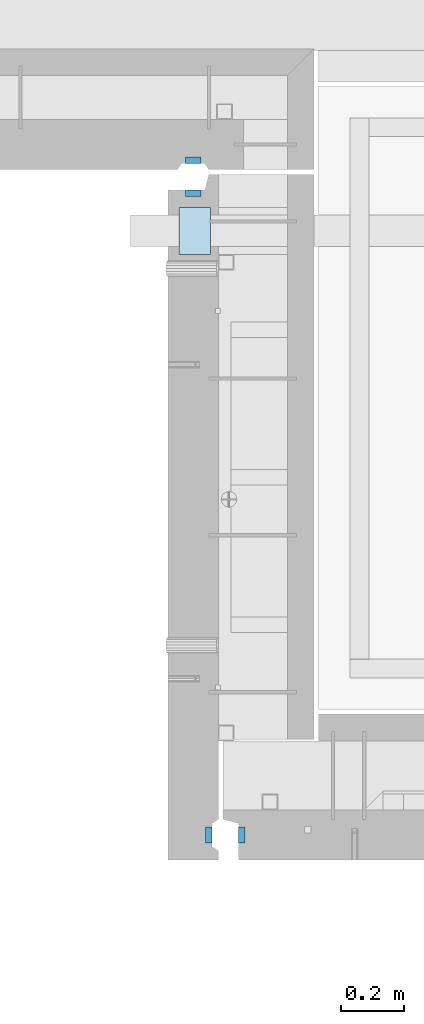
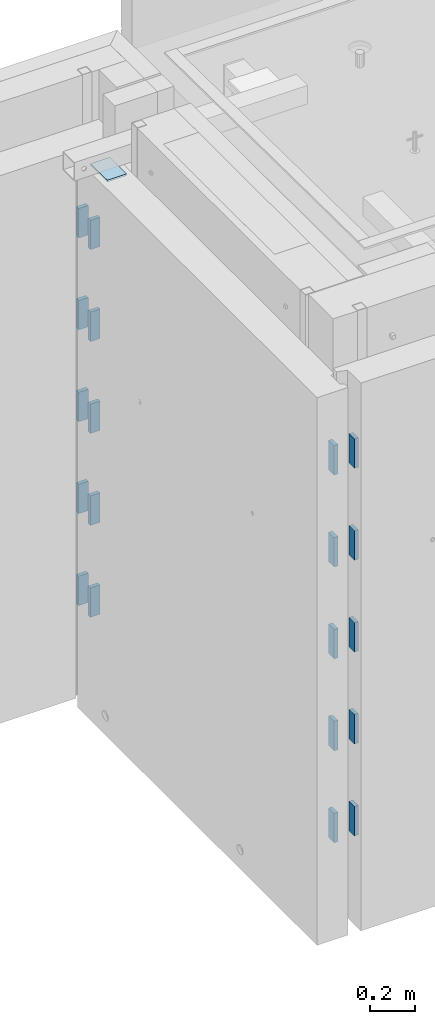
# One storey, part 167 of 264: 21 plates, 24 elements without a shape of their own.
"""IFC2X3 building model written with IfcOpenShell, lengths in millimetres."""

from ifc_helpers import new_model, si_unit, frame, origin_with_axes, place, context, subcontext, project, spatial, faceted_brep, material, type_object, element, aggregate, save


model = new_model("IFC2X3")

# Units and contexts
model_context = context("Model", 3, precision=1e-05, world=origin_with_axes())
body_context = subcontext(model_context, "Body", "Model", "MODEL_VIEW")
ifc_project = project(units=[si_unit("LENGTHUNIT", "METRE", prefix="MILLI"), si_unit("AREAUNIT", "SQUARE_METRE"), si_unit("VOLUMEUNIT", "CUBIC_METRE"), si_unit("MASSUNIT", "GRAM", prefix="KILO"), si_unit("TIMEUNIT", "SECOND"), si_unit("PLANEANGLEUNIT", "RADIAN"), si_unit("SOLIDANGLEUNIT", "STERADIAN"), si_unit("THERMODYNAMICTEMPERATUREUNIT", "DEGREE_CELSIUS"), si_unit("LUMINOUSINTENSITYUNIT", "LUMEN")], contexts=[model_context])

# Site, building, storey
site_placement = place(None, origin_with_axes())
site = spatial("IfcSite", under=ifc_project, at=site_placement, CompositionType="ELEMENT")
building_placement = place(site_placement, origin_with_axes())
building = spatial("IfcBuilding", under=site, at=building_placement, CompositionType="ELEMENT")
storey_placement = place(building_placement, origin_with_axes())
storey = spatial("IfcBuildingStorey", under=building, at=storey_placement, Name="K", CompositionType="ELEMENT", Elevation=0.0)

# Assemblies, plates
assembly_1_placement = place(storey_placement, origin_with_axes())
assembly_1 = element("IfcElementAssembly", 1, at=assembly_1_placement, inside=storey, AssemblyPlace="NOTDEFINED", PredefinedType="REINFORCEMENT_UNIT")
assembly_2_placement = place(assembly_1_placement, origin_with_axes())
assembly_2 = element("IfcElementAssembly", 2, at=assembly_2_placement, Name="Steel Assembly", AssemblyPlace="NOTDEFINED", PredefinedType="RIGID_FRAME")
ifc_material = material(Name="STEEL/Steel_Undefined")
plate_type_1 = type_object("IfcPlateType", PredefinedType="NOTDEFINED")
plate_1_placement = place(assembly_2_placement, frame((31404.996380743, 22535.0011705213, 81052.5), z_axis=(0.0, 1.0, 0.0), x_axis=(-1.0, 3.00000001838171e-08, 0.0)))
plate_1 = element("IfcPlate", 3, at=plate_1_placement, type_object=plate_type_1, material=ifc_material, Name="VL_080", context=body_context, shape_type="Brep", body=[
    faceted_brep([(0.0, -80.0, 0.0), (0.0, -80.0, 20.0), (0.0, 80.0, 20.0), (0.0, 80.0, 0.0), (50.0, -80.0, 20.0), (50.0, 80.0, 20.0), (50.0, -80.0, 0.0), (50.0, 80.0, 0.0)], [[[0, 1, 2, 3]], [[1, 4, 5, 2]], [[4, 6, 7, 5]], [[6, 0, 3, 7]], [[5, 7, 3, 2]], [[6, 4, 1, 0]]]),
])
aggregate(assembly_2, [plate_1])
assembly_3_placement = place(assembly_1_placement, origin_with_axes())
assembly_3 = element("IfcElementAssembly", 4, at=assembly_3_placement, Name="Steel Assembly", AssemblyPlace="NOTDEFINED", PredefinedType="RIGID_FRAME")
plate_2_placement = place(assembly_3_placement, frame((31404.996380743, 22535.0011705213, 80552.5), z_axis=(0.0, 1.0, 0.0), x_axis=(-1.0, 3.00000001838171e-08, 0.0)))
plate_2 = element("IfcPlate", 5, at=plate_2_placement, type_object=plate_type_1, material=ifc_material, Name="VL_080", context=body_context, shape_type="Brep", body=[
    faceted_brep([(0.0, -80.0, 0.0), (0.0, -80.0, 20.0), (0.0, 80.0, 20.0), (0.0, 80.0, 0.0), (50.0, -80.0, 20.0), (50.0, 80.0, 20.0), (50.0, -80.0, 0.0), (50.0, 80.0, 0.0)], [[[0, 1, 2, 3]], [[1, 4, 5, 2]], [[4, 6, 7, 5]], [[6, 0, 3, 7]], [[5, 7, 3, 2]], [[6, 4, 1, 0]]]),
])
aggregate(assembly_3, [plate_2])
assembly_4_placement = place(assembly_1_placement, origin_with_axes())
assembly_4 = element("IfcElementAssembly", 6, at=assembly_4_placement, Name="Steel Assembly", AssemblyPlace="NOTDEFINED", PredefinedType="RIGID_FRAME")
plate_3_placement = place(assembly_4_placement, frame((31404.996380743, 22535.0011705213, 80052.5), z_axis=(0.0, 1.0, 0.0), x_axis=(-1.0, 3.00000001838171e-08, 0.0)))
plate_3 = element("IfcPlate", 7, at=plate_3_placement, type_object=plate_type_1, material=ifc_material, Name="VL_080", context=body_context, shape_type="Brep", body=[
    faceted_brep([(0.0, -80.0, 0.0), (0.0, -80.0, 20.0), (0.0, 80.0, 20.0), (0.0, 80.0, 0.0), (50.0, -80.0, 20.0), (50.0, 80.0, 20.0), (50.0, -80.0, 0.0), (50.0, 80.0, 0.0)], [[[0, 1, 2, 3]], [[1, 4, 5, 2]], [[4, 6, 7, 5]], [[6, 0, 3, 7]], [[5, 7, 3, 2]], [[6, 4, 1, 0]]]),
])
aggregate(assembly_4, [plate_3])
assembly_5_placement = place(assembly_1_placement, origin_with_axes())
assembly_5 = element("IfcElementAssembly", 8, at=assembly_5_placement, Name="Steel Assembly", AssemblyPlace="NOTDEFINED", PredefinedType="RIGID_FRAME")
plate_4_placement = place(assembly_5_placement, frame((31404.996380743, 22535.0011705213, 79552.5), z_axis=(0.0, 1.0, 0.0), x_axis=(-1.0, 3.00000001838171e-08, 0.0)))
plate_4 = element("IfcPlate", 9, at=plate_4_placement, type_object=plate_type_1, material=ifc_material, Name="VL_080", context=body_context, shape_type="Brep", body=[
    faceted_brep([(0.0, -80.0, 0.0), (0.0, -80.0, 20.0), (0.0, 80.0, 20.0), (0.0, 80.0, 0.0), (50.0, -80.0, 20.0), (50.0, 80.0, 20.0), (50.0, -80.0, 0.0), (50.0, 80.0, 0.0)], [[[0, 1, 2, 3]], [[1, 4, 5, 2]], [[4, 6, 7, 5]], [[6, 0, 3, 7]], [[5, 7, 3, 2]], [[6, 4, 1, 0]]]),
])
aggregate(assembly_5, [plate_4])
assembly_6_placement = place(assembly_1_placement, origin_with_axes())
assembly_6 = element("IfcElementAssembly", 10, at=assembly_6_placement, Name="Steel Assembly", AssemblyPlace="NOTDEFINED", PredefinedType="RIGID_FRAME")
plate_5_placement = place(assembly_6_placement, frame((31404.996380743, 22535.0011705213, 79052.5), z_axis=(0.0, 1.0, 0.0), x_axis=(-1.0, 3.00000001838171e-08, 0.0)))
plate_5 = element("IfcPlate", 11, at=plate_5_placement, type_object=plate_type_1, material=ifc_material, Name="VL_080", context=body_context, shape_type="Brep", body=[
    faceted_brep([(0.0, -80.0, 0.0), (0.0, -80.0, 20.0), (0.0, 80.0, 20.0), (0.0, 80.0, 0.0), (50.0, -80.0, 20.0), (50.0, 80.0, 20.0), (50.0, -80.0, 0.0), (50.0, 80.0, 0.0)], [[[0, 1, 2, 3]], [[1, 4, 5, 2]], [[4, 6, 7, 5]], [[6, 0, 3, 7]], [[5, 7, 3, 2]], [[6, 4, 1, 0]]]),
])
aggregate(assembly_6, [plate_5])

assembly_7_placement = place(storey_placement, origin_with_axes())
assembly_7 = element("IfcElementAssembly", 12, at=assembly_7_placement, inside=storey, AssemblyPlace="NOTDEFINED", PredefinedType="REINFORCEMENT_UNIT")
assembly_8_placement = place(assembly_7_placement, origin_with_axes())
assembly_8 = element("IfcElementAssembly", 13, at=assembly_8_placement, Name="Steel Assembly", AssemblyPlace="NOTDEFINED", PredefinedType="RIGID_FRAME")
plate_6_placement = place(assembly_8_placement, frame((31354.9963411181, 22660.0011546714, 81052.5), z_axis=(0.0, -1.0, 0.0), x_axis=(1.0, 0.0, 0.0)))
plate_6 = element("IfcPlate", 14, at=plate_6_placement, type_object=plate_type_1, material=ifc_material, Name="VL_080", context=body_context, shape_type="Brep", body=[
    faceted_brep([(0.0, -80.0, 0.0), (0.0, -80.0, 20.0), (0.0, 80.0, 20.0), (0.0, 80.0, 0.0), (50.0, -80.0, 20.0), (50.0, 80.0, 20.0), (50.0, -80.0, 0.0), (50.0, 80.0, 0.0)], [[[0, 1, 2, 3]], [[1, 4, 5, 2]], [[4, 6, 7, 5]], [[6, 0, 3, 7]], [[5, 7, 3, 2]], [[6, 4, 1, 0]]]),
])
aggregate(assembly_8, [plate_6])
assembly_9_placement = place(assembly_7_placement, origin_with_axes())
assembly_9 = element("IfcElementAssembly", 15, at=assembly_9_placement, Name="Steel Assembly", AssemblyPlace="NOTDEFINED", PredefinedType="RIGID_FRAME")
plate_7_placement = place(assembly_9_placement, frame((31354.9963411181, 22660.0011546714, 80552.5), z_axis=(0.0, -1.0, 0.0), x_axis=(1.0, 0.0, 0.0)))
plate_7 = element("IfcPlate", 16, at=plate_7_placement, type_object=plate_type_1, material=ifc_material, Name="VL_080", context=body_context, shape_type="Brep", body=[
    faceted_brep([(0.0, -80.0, 0.0), (0.0, -80.0, 20.0), (0.0, 80.0, 20.0), (0.0, 80.0, 0.0), (50.0, -80.0, 20.0), (50.0, 80.0, 20.0), (50.0, -80.0, 0.0), (50.0, 80.0, 0.0)], [[[0, 1, 2, 3]], [[1, 4, 5, 2]], [[4, 6, 7, 5]], [[6, 0, 3, 7]], [[5, 7, 3, 2]], [[6, 4, 1, 0]]]),
])
aggregate(assembly_9, [plate_7])
assembly_10_placement = place(assembly_7_placement, origin_with_axes())
assembly_10 = element("IfcElementAssembly", 17, at=assembly_10_placement, Name="Steel Assembly", AssemblyPlace="NOTDEFINED", PredefinedType="RIGID_FRAME")
plate_8_placement = place(assembly_10_placement, frame((31354.9963411181, 22660.0011546714, 80052.5), z_axis=(0.0, -1.0, 0.0), x_axis=(1.0, 0.0, 0.0)))
plate_8 = element("IfcPlate", 18, at=plate_8_placement, type_object=plate_type_1, material=ifc_material, Name="VL_080", context=body_context, shape_type="Brep", body=[
    faceted_brep([(0.0, -80.0, 0.0), (0.0, -80.0, 20.0), (0.0, 80.0, 20.0), (0.0, 80.0, 0.0), (50.0, -80.0, 20.0), (50.0, 80.0, 20.0), (50.0, -80.0, 0.0), (50.0, 80.0, 0.0)], [[[0, 1, 2, 3]], [[1, 4, 5, 2]], [[4, 6, 7, 5]], [[6, 0, 3, 7]], [[5, 7, 3, 2]], [[6, 4, 1, 0]]]),
])
aggregate(assembly_10, [plate_8])
assembly_11_placement = place(assembly_7_placement, origin_with_axes())
assembly_11 = element("IfcElementAssembly", 19, at=assembly_11_placement, Name="Steel Assembly", AssemblyPlace="NOTDEFINED", PredefinedType="RIGID_FRAME")
plate_9_placement = place(assembly_11_placement, frame((31354.9963411181, 22660.0011546714, 79552.5), z_axis=(0.0, -1.0, 0.0), x_axis=(1.0, 0.0, 0.0)))
plate_9 = element("IfcPlate", 20, at=plate_9_placement, type_object=plate_type_1, material=ifc_material, Name="VL_080", context=body_context, shape_type="Brep", body=[
    faceted_brep([(0.0, -80.0, 0.0), (0.0, -80.0, 20.0), (0.0, 80.0, 20.0), (0.0, 80.0, 0.0), (50.0, -80.0, 20.0), (50.0, 80.0, 20.0), (50.0, -80.0, 0.0), (50.0, 80.0, 0.0)], [[[0, 1, 2, 3]], [[1, 4, 5, 2]], [[4, 6, 7, 5]], [[6, 0, 3, 7]], [[5, 7, 3, 2]], [[6, 4, 1, 0]]]),
])
aggregate(assembly_11, [plate_9])
assembly_12_placement = place(assembly_7_placement, origin_with_axes())
assembly_12 = element("IfcElementAssembly", 21, at=assembly_12_placement, Name="Steel Assembly", AssemblyPlace="NOTDEFINED", PredefinedType="RIGID_FRAME")
aggregate(assembly_7, [assembly_8, assembly_9, assembly_10, assembly_11, assembly_12])
plate_10_placement = place(assembly_12_placement, frame((31354.9963411181, 22660.0011546714, 79052.5), z_axis=(0.0, -1.0, 0.0), x_axis=(1.0, 0.0, 0.0)))
plate_10 = element("IfcPlate", 22, at=plate_10_placement, type_object=plate_type_1, material=ifc_material, Name="VL_080", context=body_context, shape_type="Brep", body=[
    faceted_brep([(0.0, -80.0, 0.0), (0.0, -80.0, 20.0), (0.0, 80.0, 20.0), (0.0, 80.0, 0.0), (50.0, -80.0, 20.0), (50.0, 80.0, 20.0), (50.0, -80.0, 0.0), (50.0, 80.0, 0.0)], [[[0, 1, 2, 3]], [[1, 4, 5, 2]], [[4, 6, 7, 5]], [[6, 0, 3, 7]], [[5, 7, 3, 2]], [[6, 4, 1, 0]]]),
])
aggregate(assembly_12, [plate_10])

assembly_13_placement = place(storey_placement, origin_with_axes())
assembly_13 = element("IfcElementAssembly", 23, at=assembly_13_placement, inside=storey, AssemblyPlace="NOTDEFINED", PredefinedType="REINFORCEMENT_UNIT")
assembly_14_placement = place(assembly_13_placement, origin_with_axes())
assembly_14 = element("IfcElementAssembly", 24, at=assembly_14_placement, Name="Steel Assembly", AssemblyPlace="NOTDEFINED", PredefinedType="RIGID_FRAME")
plate_11_placement = place(assembly_14_placement, frame((31544.9952434474, 20524.9999549501, 81052.5000000001), z_axis=(-1.0, 3.00000001838171e-08, 0.0), x_axis=(0.0, -1.0, 0.0)))
plate_11 = element("IfcPlate", 25, at=plate_11_placement, type_object=plate_type_1, material=ifc_material, Name="VL_080", context=body_context, shape_type="Brep", body=[
    faceted_brep([(0.0, -80.0, 0.0), (0.0, -80.0, 20.0), (0.0, 80.0, 20.0), (0.0, 80.0, 0.0), (50.0, -80.0, 20.0), (50.0, 80.0, 20.0), (50.0, -80.0, 0.0), (50.0, 80.0, 0.0)], [[[0, 1, 2, 3]], [[1, 4, 5, 2]], [[4, 6, 7, 5]], [[6, 0, 3, 7]], [[5, 7, 3, 2]], [[6, 4, 1, 0]]]),
])
aggregate(assembly_14, [plate_11])
assembly_15_placement = place(assembly_13_placement, origin_with_axes())
assembly_15 = element("IfcElementAssembly", 26, at=assembly_15_placement, Name="Steel Assembly", AssemblyPlace="NOTDEFINED", PredefinedType="RIGID_FRAME")
plate_12_placement = place(assembly_15_placement, frame((31544.9952434474, 20524.9999549501, 80552.5000000001), z_axis=(-1.0, 3.00000001838171e-08, 0.0), x_axis=(0.0, -1.0, 0.0)))
plate_12 = element("IfcPlate", 27, at=plate_12_placement, type_object=plate_type_1, material=ifc_material, Name="VL_080", context=body_context, shape_type="Brep", body=[
    faceted_brep([(0.0, -80.0, 0.0), (0.0, -80.0, 20.0), (0.0, 80.0, 20.0), (0.0, 80.0, 0.0), (50.0, -80.0, 20.0), (50.0, 80.0, 20.0), (50.0, -80.0, 0.0), (50.0, 80.0, 0.0)], [[[0, 1, 2, 3]], [[1, 4, 5, 2]], [[4, 6, 7, 5]], [[6, 0, 3, 7]], [[5, 7, 3, 2]], [[6, 4, 1, 0]]]),
])
aggregate(assembly_15, [plate_12])
assembly_16_placement = place(assembly_13_placement, origin_with_axes())
assembly_16 = element("IfcElementAssembly", 28, at=assembly_16_placement, Name="Steel Assembly", AssemblyPlace="NOTDEFINED", PredefinedType="RIGID_FRAME")
plate_13_placement = place(assembly_16_placement, frame((31544.9952434474, 20524.9999549501, 80052.5000000001), z_axis=(-1.0, 3.00000001838171e-08, 0.0), x_axis=(0.0, -1.0, 0.0)))
plate_13 = element("IfcPlate", 29, at=plate_13_placement, type_object=plate_type_1, material=ifc_material, Name="VL_080", context=body_context, shape_type="Brep", body=[
    faceted_brep([(0.0, -80.0, 0.0), (0.0, -80.0, 20.0), (0.0, 80.0, 20.0), (0.0, 80.0, 0.0), (50.0, -80.0, 20.0), (50.0, 80.0, 20.0), (50.0, -80.0, 0.0), (50.0, 80.0, 0.0)], [[[0, 1, 2, 3]], [[1, 4, 5, 2]], [[4, 6, 7, 5]], [[6, 0, 3, 7]], [[5, 7, 3, 2]], [[6, 4, 1, 0]]]),
])
aggregate(assembly_16, [plate_13])
assembly_17_placement = place(assembly_13_placement, origin_with_axes())
assembly_17 = element("IfcElementAssembly", 30, at=assembly_17_placement, Name="Steel Assembly", AssemblyPlace="NOTDEFINED", PredefinedType="RIGID_FRAME")
plate_14_placement = place(assembly_17_placement, frame((31544.9952434474, 20524.9999549501, 79552.5000000001), z_axis=(-1.0, 3.00000001838171e-08, 0.0), x_axis=(0.0, -1.0, 0.0)))
plate_14 = element("IfcPlate", 31, at=plate_14_placement, type_object=plate_type_1, material=ifc_material, Name="VL_080", context=body_context, shape_type="Brep", body=[
    faceted_brep([(0.0, -80.0, 0.0), (0.0, -80.0, 20.0), (0.0, 80.0, 20.0), (0.0, 80.0, 0.0), (50.0, -80.0, 20.0), (50.0, 80.0, 20.0), (50.0, -80.0, 0.0), (50.0, 80.0, 0.0)], [[[0, 1, 2, 3]], [[1, 4, 5, 2]], [[4, 6, 7, 5]], [[6, 0, 3, 7]], [[5, 7, 3, 2]], [[6, 4, 1, 0]]]),
])
aggregate(assembly_17, [plate_14])
assembly_18_placement = place(assembly_13_placement, origin_with_axes())
assembly_18 = element("IfcElementAssembly", 32, at=assembly_18_placement, Name="Steel Assembly", AssemblyPlace="NOTDEFINED", PredefinedType="RIGID_FRAME")
aggregate(assembly_13, [assembly_14, assembly_15, assembly_16, assembly_17, assembly_18])
plate_15_placement = place(assembly_18_placement, frame((31544.9952434474, 20524.9999549501, 79052.5000000001), z_axis=(-1.0, 3.00000001838171e-08, 0.0), x_axis=(0.0, -1.0, 0.0)))
plate_15 = element("IfcPlate", 33, at=plate_15_placement, type_object=plate_type_1, material=ifc_material, Name="VL_080", context=body_context, shape_type="Brep", body=[
    faceted_brep([(0.0, -80.0, 0.0), (0.0, -80.0, 20.0), (0.0, 80.0, 20.0), (0.0, 80.0, 0.0), (50.0, -80.0, 20.0), (50.0, 80.0, 20.0), (50.0, -80.0, 0.0), (50.0, 80.0, 0.0)], [[[0, 1, 2, 3]], [[1, 4, 5, 2]], [[4, 6, 7, 5]], [[6, 0, 3, 7]], [[5, 7, 3, 2]], [[6, 4, 1, 0]]]),
])
aggregate(assembly_18, [plate_15])

# Assembly, plate
assembly_19_placement = place(assembly_1_placement, origin_with_axes())
assembly_19 = element("IfcElementAssembly", 34, at=assembly_19_placement, Name="Steel Assembly", AssemblyPlace="NOTDEFINED", PredefinedType="RIGID_FRAME")
plate_16_placement = place(assembly_19_placement, frame((31419.9952169475, 20475.0000211999, 81052.5000000001), z_axis=(1.0, 0.0, 0.0), x_axis=(0.0, 1.0, 0.0)))
plate_16 = element("IfcPlate", 35, at=plate_16_placement, type_object=plate_type_1, material=ifc_material, Name="VL_080", context=body_context, shape_type="Brep", body=[
    faceted_brep([(0.0, -80.0, 0.0), (0.0, -80.0, 20.0), (0.0, 80.0, 20.0), (0.0, 80.0, 0.0), (50.0, -80.0, 20.0), (50.0, 80.0, 20.0), (50.0, -80.0, 0.0), (50.0, 80.0, 0.0)], [[[0, 1, 2, 3]], [[1, 4, 5, 2]], [[4, 6, 7, 5]], [[6, 0, 3, 7]], [[5, 7, 3, 2]], [[6, 4, 1, 0]]]),
])
aggregate(assembly_19, [plate_16])

assembly_20_placement = place(assembly_1_placement, origin_with_axes())
assembly_20 = element("IfcElementAssembly", 36, at=assembly_20_placement, Name="Steel Assembly", AssemblyPlace="NOTDEFINED", PredefinedType="RIGID_FRAME")
plate_17_placement = place(assembly_20_placement, frame((31419.9952169475, 20475.0000211999, 80552.5000000001), z_axis=(1.0, 0.0, 0.0), x_axis=(0.0, 1.0, 0.0)))
plate_17 = element("IfcPlate", 37, at=plate_17_placement, type_object=plate_type_1, material=ifc_material, Name="VL_080", context=body_context, shape_type="Brep", body=[
    faceted_brep([(0.0, -80.0, 0.0), (0.0, -80.0, 20.0), (0.0, 80.0, 20.0), (0.0, 80.0, 0.0), (50.0, -80.0, 20.0), (50.0, 80.0, 20.0), (50.0, -80.0, 0.0), (50.0, 80.0, 0.0)], [[[0, 1, 2, 3]], [[1, 4, 5, 2]], [[4, 6, 7, 5]], [[6, 0, 3, 7]], [[5, 7, 3, 2]], [[6, 4, 1, 0]]]),
])
aggregate(assembly_20, [plate_17])

assembly_21_placement = place(assembly_1_placement, origin_with_axes())
assembly_21 = element("IfcElementAssembly", 38, at=assembly_21_placement, Name="Steel Assembly", AssemblyPlace="NOTDEFINED", PredefinedType="RIGID_FRAME")
plate_18_placement = place(assembly_21_placement, frame((31419.9952169475, 20475.0000211999, 80052.5000000001), z_axis=(1.0, 0.0, 0.0), x_axis=(0.0, 1.0, 0.0)))
plate_18 = element("IfcPlate", 39, at=plate_18_placement, type_object=plate_type_1, material=ifc_material, Name="VL_080", context=body_context, shape_type="Brep", body=[
    faceted_brep([(0.0, -80.0, 0.0), (0.0, -80.0, 20.0), (0.0, 80.0, 20.0), (0.0, 80.0, 0.0), (50.0, -80.0, 20.0), (50.0, 80.0, 20.0), (50.0, -80.0, 0.0), (50.0, 80.0, 0.0)], [[[0, 1, 2, 3]], [[1, 4, 5, 2]], [[4, 6, 7, 5]], [[6, 0, 3, 7]], [[5, 7, 3, 2]], [[6, 4, 1, 0]]]),
])
aggregate(assembly_21, [plate_18])

assembly_22_placement = place(assembly_1_placement, origin_with_axes())
assembly_22 = element("IfcElementAssembly", 40, at=assembly_22_placement, Name="Steel Assembly", AssemblyPlace="NOTDEFINED", PredefinedType="RIGID_FRAME")
plate_19_placement = place(assembly_22_placement, frame((31419.9952169475, 20475.0000211999, 79552.5000000001), z_axis=(1.0, 0.0, 0.0), x_axis=(0.0, 1.0, 0.0)))
plate_19 = element("IfcPlate", 41, at=plate_19_placement, type_object=plate_type_1, material=ifc_material, Name="VL_080", context=body_context, shape_type="Brep", body=[
    faceted_brep([(0.0, -80.0, 0.0), (0.0, -80.0, 20.0), (0.0, 80.0, 20.0), (0.0, 80.0, 0.0), (50.0, -80.0, 20.0), (50.0, 80.0, 20.0), (50.0, -80.0, 0.0), (50.0, 80.0, 0.0)], [[[0, 1, 2, 3]], [[1, 4, 5, 2]], [[4, 6, 7, 5]], [[6, 0, 3, 7]], [[5, 7, 3, 2]], [[6, 4, 1, 0]]]),
])
aggregate(assembly_22, [plate_19])

assembly_23_placement = place(assembly_1_placement, origin_with_axes())
assembly_23 = element("IfcElementAssembly", 42, at=assembly_23_placement, Name="Steel Assembly", AssemblyPlace="NOTDEFINED", PredefinedType="RIGID_FRAME")
plate_20_placement = place(assembly_23_placement, frame((31419.9952169475, 20475.0000211999, 79052.5000000001), z_axis=(1.0, 0.0, 0.0), x_axis=(0.0, 1.0, 0.0)))
plate_20 = element("IfcPlate", 43, at=plate_20_placement, type_object=plate_type_1, material=ifc_material, Name="VL_080", context=body_context, shape_type="Brep", body=[
    faceted_brep([(0.0, -80.0, 0.0), (0.0, -80.0, 20.0), (0.0, 80.0, 20.0), (0.0, 80.0, 0.0), (50.0, -80.0, 20.0), (50.0, 80.0, 20.0), (50.0, -80.0, 0.0), (50.0, 80.0, 0.0)], [[[0, 1, 2, 3]], [[1, 4, 5, 2]], [[4, 6, 7, 5]], [[6, 0, 3, 7]], [[5, 7, 3, 2]], [[6, 4, 1, 0]]]),
])
aggregate(assembly_23, [plate_20])

# Assembly
assembly_24_placement = place(assembly_1_placement, origin_with_axes())
assembly_24 = element("IfcElementAssembly", 44, at=assembly_24_placement, Name="Steel Assembly", AssemblyPlace="NOTDEFINED", PredefinedType="RIGID_FRAME")

aggregate(assembly_1, [assembly_24, assembly_2, assembly_3, assembly_4, assembly_5, assembly_6, assembly_19, assembly_20, assembly_21, assembly_22, assembly_23])

# Plate
plate_type_2 = type_object("IfcPlateType", PredefinedType="NOTDEFINED")
plate_21_placement = place(assembly_24_placement, frame((31334.9951872276, 22350.0, 81465.0), z_axis=(0.0, 1.0, 0.0), x_axis=(1.0, 0.0, 0.0)))
plate_21 = element("IfcPlate", 45, at=plate_21_placement, type_object=plate_type_2, material=ifc_material, Name="KL100x150", context=body_context, shape_type="Brep", body=[
    faceted_brep([(0.0, -5.0, 0.0), (7.27595761418343e-11, -5.0, 150.0), (7.27595761418343e-11, 5.0, 150.0), (0.0, 5.0, 0.0), (100.0, -5.0, 150.0), (100.0, 5.0, 150.0), (100.0, -5.0, 0.0), (100.0, 5.0, 0.0)], [[[0, 1, 2, 3]], [[1, 4, 5, 2]], [[4, 6, 7, 5]], [[6, 0, 3, 7]], [[5, 7, 3, 2]], [[6, 4, 1, 0]]]),
])

aggregate(assembly_24, [plate_21])

save(model, "model.ifc")
